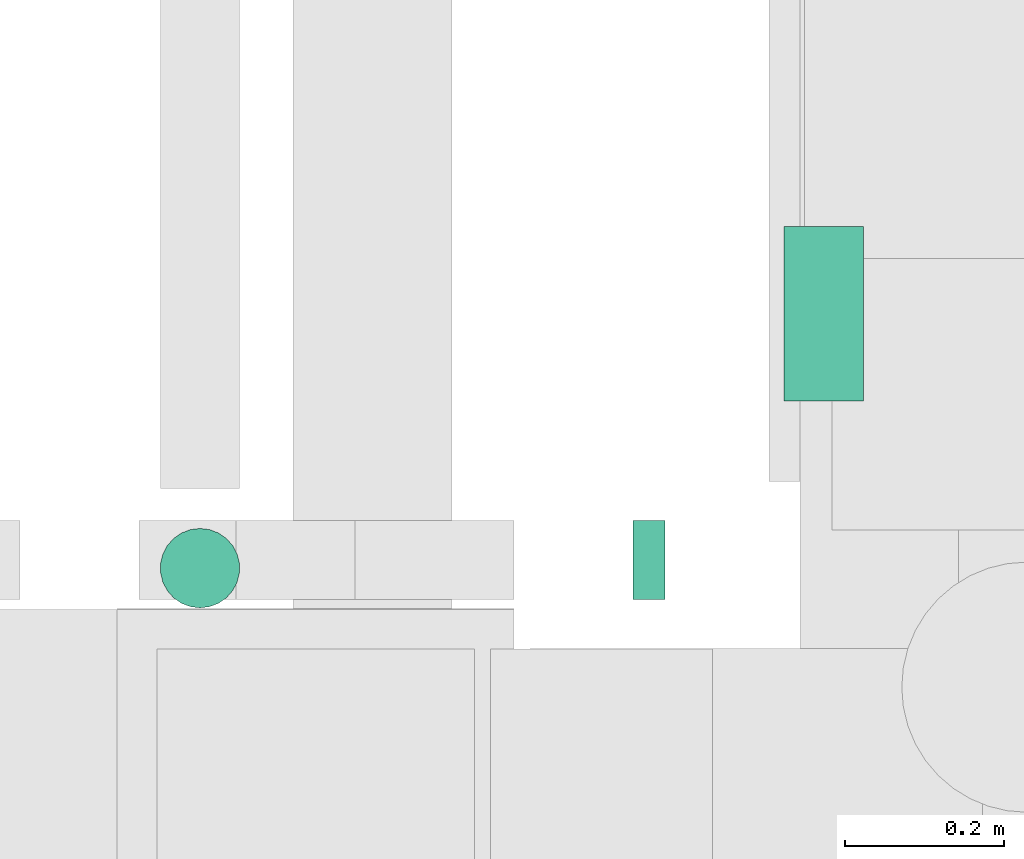
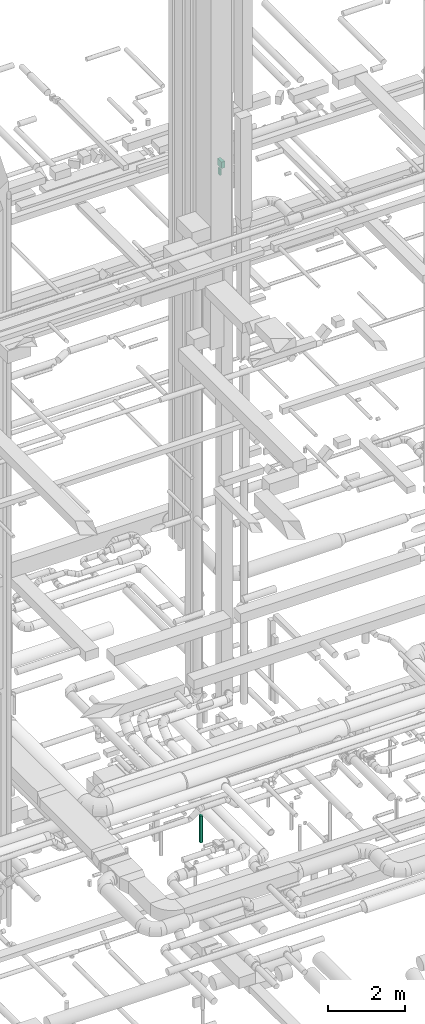
# One storey, part 199 of 337: 3 flow segments.
"""IFC2X3 building model written with IfcOpenShell, lengths in millimetres."""

import ifcopenshell
import ifcopenshell.guid

model = None  # the IFC model being written
_history = None  # IfcOwnerHistory: only IFC2X3 demands one
_inside = {}  # id of a spatial element -> (the spatial element, [elements in it])
_under = {}  # id of a project, library or spatial element -> (it, [spatial elements below it])
_declared = {}  # id of a project -> (the project, [libraries it declares])
_typed = {}  # id of a type object -> (the type object, [elements of that type])
_made_of = {}  # id of a material, layer set ... -> (it, [elements and type objects made of it])


def new_model(schema):
    """Start an empty IFC model of exactly this schema.

    Asked for "IFC4X3", IfcOpenShell would pick the latest addendum, in which some entities
    have other attributes; the version numbers below select the first issue.
    IFC2X3 requires an IfcOwnerHistory on every rooted entity: one is made here for all.
    """
    global model, _history
    if schema == "IFC4X3":
        model = ifcopenshell.file(schema_version=(4, 3, 0, 0))
    else:
        model = ifcopenshell.file(schema=schema)
    _inside.clear()
    _under.clear()
    _declared.clear()
    _typed.clear()
    _made_of.clear()
    _history = None
    if model.schema == "IFC2X3":
        org = make("IfcOrganization", Name="unknown")
        user = make(
            "IfcPersonAndOrganization",
            ThePerson=make("IfcPerson", FamilyName="unknown"),
            TheOrganization=org,
        )
        app = make(
            "IfcApplication",
            ApplicationDeveloper=org,
            Version="unknown",
            ApplicationFullName="unknown",
            ApplicationIdentifier="unknown",
        )
        _history = make(
            "IfcOwnerHistory",
            OwningUser=user,
            OwningApplication=app,
            ChangeAction="ADDED",
            CreationDate=0,
        )
    return model


def make(cls, **values):
    """One entity of the class cls with the attributes given. An attribute that is None is left unset."""
    return model.create_entity(
        cls, **{name: value for name, value in values.items() if value is not None}
    )


def entity(cls, *values):
    """Any entity or typed value of the class cls, its attributes in the order of the schema. None: left unset."""
    e = model.create_entity(cls)
    for i, value in enumerate(values):
        if value is not None:
            e[i] = value
    return e


def rooted(cls, **values):
    """An entity with a GlobalId (a new one), such as an element, a storey or a relation."""
    return make(cls, GlobalId=ifcopenshell.guid.new(), OwnerHistory=_history, **values)


def si_unit(unit_type, name, prefix=None):
    """IfcSIUnit, for example si_unit("LENGTHUNIT", "METRE", prefix="MILLI")."""
    return make("IfcSIUnit", UnitType=unit_type, Prefix=prefix, Name=name)


def converted_unit(unit_type, name, factor, base, dimensions=None, offset=None):
    """IfcConversionBasedUnit, such as the inch: factor (a typed value) times the base unit."""
    return make(
        "IfcConversionBasedUnit"
        if offset is None
        else "IfcConversionBasedUnitWithOffset",
        ConversionOffset=offset,
        Dimensions=None
        if dimensions is None
        else entity("IfcDimensionalExponents", *dimensions),
        UnitType=unit_type,
        Name=name,
        ConversionFactor=make(
            "IfcMeasureWithUnit", ValueComponent=factor, UnitComponent=base
        ),
    )


def derived_unit(unit_type, elements):
    """IfcDerivedUnit: a product of units, each with its exponent."""
    return make(
        "IfcDerivedUnit",
        Elements=[
            make("IfcDerivedUnitElement", Unit=unit, Exponent=power)
            for unit, power in elements
        ],
        UnitType=unit_type,
    )


def assignment(units):
    """IfcUnitAssignment: the units of a project."""
    return None if units is None else make("IfcUnitAssignment", Units=units)


def point(xyz):
    """IfcCartesianPoint."""
    return None if xyz is None else make("IfcCartesianPoint", Coordinates=xyz)


def direction(xyz):
    """IfcDirection."""
    return None if xyz is None else make("IfcDirection", DirectionRatios=xyz)


def frame(location, z_axis=None, x_axis=None):
    """IfcAxis2Placement3D, a coordinate frame: its origin and axes. An axis left out is left unset."""
    return make(
        "IfcAxis2Placement3D",
        Location=point(location),
        Axis=direction(z_axis),
        RefDirection=direction(x_axis),
    )


def frame_2d(location, x_axis=None):
    """IfcAxis2Placement2D, a coordinate frame in the plane: its origin and x axis."""
    return make(
        "IfcAxis2Placement2D", Location=point(location), RefDirection=direction(x_axis)
    )


def origin():
    """The frame at (0, 0, 0) with its axes left unset."""
    return frame((0.0, 0.0, 0.0))


def origin_2d_with_axis():
    """The frame at (0, 0) in the plane with the x axis (1, 0) written out."""
    return frame_2d((0.0, 0.0), x_axis=(1.0, 0.0))


def place(relative_to, where):
    """IfcLocalPlacement: puts the frame where relative to a parent placement (None: the world)."""
    return make(
        "IfcLocalPlacement", PlacementRelTo=relative_to, RelativePlacement=where
    )


def context(
    kind, dimensions, precision=None, world=None, true_north=None, identifier=None
):
    """IfcGeometricRepresentationContext, for example the 3D "Model" context."""
    return make(
        "IfcGeometricRepresentationContext",
        ContextIdentifier=identifier,
        ContextType=kind,
        CoordinateSpaceDimension=dimensions,
        Precision=precision,
        WorldCoordinateSystem=world,
        TrueNorth=true_north,
    )


def subcontext(parent, identifier, kind, view, scale=None):
    """IfcGeometricRepresentationSubContext, for example "Body" below "Model"."""
    return make(
        "IfcGeometricRepresentationSubContext",
        ContextIdentifier=identifier,
        ContextType=kind,
        ParentContext=parent,
        TargetScale=scale,
        TargetView=view,
    )


def project(units=None, contexts=None):
    """IfcProject with its units and contexts."""
    return rooted(
        "IfcProject",
        Name="project",
        RepresentationContexts=contexts,
        UnitsInContext=assignment(units),
    )


def spatial(cls, under=None, at=None, **own):
    """A site, building, storey or space (cls), placed at a placement, below another one or the project."""
    s = rooted(cls, ObjectPlacement=at, **own)
    if under is not None:
        _under.setdefault(under.id(), (under, []))[1].append(s)
    return s


def profile(cls, at=None, kind="AREA", **sizes):
    """A parametric profile (cls). Its sizes go by their IFC names, for example OverallWidth=200.0."""
    return make(cls, ProfileType=kind, Position=at, **sizes)


def rectangle(**sizes):
    """IfcRectangleProfileDef."""
    return profile("IfcRectangleProfileDef", **sizes)


def circle(**sizes):
    """IfcCircleProfileDef."""
    return profile("IfcCircleProfileDef", **sizes)


def extrude(swept, where, along, depth):
    """IfcExtrudedAreaSolid: the profile swept, set in the frame where, extruded along a direction by depth."""
    return make(
        "IfcExtrudedAreaSolid",
        SweptArea=swept,
        Position=where,
        ExtrudedDirection=direction(along),
        Depth=depth,
    )


def shape(context_of_items, identifier, shape_type, items):
    """IfcShapeRepresentation: the items that make up one representation, for example the "Body"."""
    return make(
        "IfcShapeRepresentation",
        ContextOfItems=context_of_items,
        RepresentationIdentifier=identifier,
        RepresentationType=shape_type,
        Items=items,
    )


def made_of(thing, what):
    """Note that an element or type object is made of a material, layer set ...; save() writes the relation."""
    if what is not None:
        _made_of.setdefault(what.id(), (what, []))[1].append(thing)
    return thing


def type_object(cls, material=None, **own):
    """A type object (cls), such as IfcWallType, which elements share."""
    return made_of(rooted(cls, **own), material)


def element(
    cls,
    number,
    at=None,
    inside=None,
    cuts=None,
    type_object=None,
    material=None,
    context=None,
    identifier="Body",
    shape_type=None,
    held_by="IfcProductDefinitionShape",
    body=None,
    shapes=None,
    **own,
):
    """One element of the class cls, such as IfcWall. Its Tag is "e" and its number.

    at: its placement. inside: the storey or other place that contains it. cuts: it is an
    opening in that element (IfcRelVoidsElement). A single representation is given by context,
    identifier, shape_type and body (its items); several are given by shapes. held_by: the class
    of the entity that holds the representations. save() writes the other relations.
    """
    e = rooted(cls, Tag="e%d" % number, ObjectPlacement=at, **own)
    if body is not None:
        shapes = [shape(context, identifier, shape_type, body)]
    if shapes is not None:
        e.Representation = make(held_by, Representations=shapes)
    if inside is not None:
        _inside.setdefault(inside.id(), (inside, []))[1].append(e)
    if cuts is not None:
        rooted(
            "IfcRelVoidsElement", RelatingBuildingElement=cuts, RelatedOpeningElement=e
        )
    if type_object is not None:
        _typed.setdefault(type_object.id(), (type_object, []))[1].append(e)
    return made_of(e, material)


def aggregate(whole, parts):
    """IfcRelAggregates: a whole, such as a stair, and the parts it consists of."""
    return rooted("IfcRelAggregates", RelatingObject=whole, RelatedObjects=parts)


def save(model, path):
    """Write the relations noted so far, then the file.

    IfcRelAggregates (storeys below a building ...), IfcRelContainedInSpatialStructure (elements
    in a storey), IfcRelDefinesByType, IfcRelAssociatesMaterial and IfcRelDeclares: one each for
    every whole, place, type object, material and project.
    """
    for whole, parts in _under.values():
        aggregate(whole, parts)
    for where, things in _inside.values():
        rooted(
            "IfcRelContainedInSpatialStructure",
            RelatedElements=things,
            RelatingStructure=where,
        )
    for kind, things in _typed.values():
        rooted("IfcRelDefinesByType", RelatedObjects=things, RelatingType=kind)
    for what, things in _made_of.values():
        rooted("IfcRelAssociatesMaterial", RelatedObjects=things, RelatingMaterial=what)
    for by, libraries in _declared.values():
        rooted("IfcRelDeclares", RelatingContext=by, RelatedDefinitions=libraries)
    model.write(path)


model = new_model("IFC2X3")

# Units and contexts
model_context = context("Model", 3, precision=0.01, world=origin(), true_north=direction((6.12303176911189e-17, 1.0)))
body_context = subcontext(model_context, "Body", "Model", "MODEL_VIEW")
ifc_project = project(units=[si_unit("LENGTHUNIT", "METRE", prefix="MILLI"), si_unit("AREAUNIT", "SQUARE_METRE"), si_unit("VOLUMEUNIT", "CUBIC_METRE"), converted_unit("PLANEANGLEUNIT", "DEGREE", entity("IfcRatioMeasure", 0.0174532925199433), si_unit("PLANEANGLEUNIT", "RADIAN"), dimensions=[0, 0, 0, 0, 0, 0, 0]), si_unit("MASSUNIT", "GRAM", prefix="KILO"), derived_unit("MASSDENSITYUNIT", [(si_unit("MASSUNIT", "GRAM", prefix="KILO"), 1), (si_unit("LENGTHUNIT", "METRE"), -3)]), derived_unit("MOMENTOFINERTIAUNIT", [(si_unit("LENGTHUNIT", "METRE"), 4)]), si_unit("TIMEUNIT", "SECOND"), si_unit("FREQUENCYUNIT", "HERTZ"), si_unit("THERMODYNAMICTEMPERATUREUNIT", "DEGREE_CELSIUS"), derived_unit("THERMALTRANSMITTANCEUNIT", [(si_unit("MASSUNIT", "GRAM", prefix="KILO"), 1), (si_unit("THERMODYNAMICTEMPERATUREUNIT", "KELVIN"), -1), (si_unit("TIMEUNIT", "SECOND"), -3)]), derived_unit("VOLUMETRICFLOWRATEUNIT", [(si_unit("LENGTHUNIT", "METRE"), 3), (si_unit("TIMEUNIT", "SECOND"), -1)]), derived_unit("MASSFLOWRATEUNIT", [(si_unit("MASSUNIT", "GRAM", prefix="KILO"), 1), (si_unit("TIMEUNIT", "SECOND"), -1)]), derived_unit("ROTATIONALFREQUENCYUNIT", [(si_unit("TIMEUNIT", "SECOND"), -1)]), si_unit("ELECTRICCURRENTUNIT", "AMPERE"), si_unit("ELECTRICVOLTAGEUNIT", "VOLT"), si_unit("POWERUNIT", "WATT"), si_unit("FORCEUNIT", "NEWTON", prefix="KILO"), si_unit("ILLUMINANCEUNIT", "LUX"), si_unit("LUMINOUSFLUXUNIT", "LUMEN"), si_unit("LUMINOUSINTENSITYUNIT", "CANDELA"), derived_unit("USERDEFINED", [(si_unit("MASSUNIT", "GRAM", prefix="KILO"), -1), (si_unit("LENGTHUNIT", "METRE"), -2), (si_unit("TIMEUNIT", "SECOND"), 3), (si_unit("LUMINOUSFLUXUNIT", "LUMEN"), 1)]), derived_unit("LINEARVELOCITYUNIT", [(si_unit("LENGTHUNIT", "METRE"), 1), (si_unit("TIMEUNIT", "SECOND"), -1)]), si_unit("PRESSUREUNIT", "PASCAL"), derived_unit("USERDEFINED", [(si_unit("LENGTHUNIT", "METRE"), -2), (si_unit("MASSUNIT", "GRAM", prefix="KILO"), 1), (si_unit("TIMEUNIT", "SECOND"), -2)]), derived_unit("LINEARFORCEUNIT", [(si_unit("MASSUNIT", "GRAM", prefix="KILO"), 1), (si_unit("LENGTHUNIT", "METRE"), 1), (si_unit("TIMEUNIT", "SECOND"), -2), (si_unit("LENGTHUNIT", "METRE"), -1)]), derived_unit("PLANARFORCEUNIT", [(si_unit("MASSUNIT", "GRAM", prefix="KILO"), 1), (si_unit("LENGTHUNIT", "METRE"), 1), (si_unit("TIMEUNIT", "SECOND"), -2), (si_unit("LENGTHUNIT", "METRE"), -2)])], contexts=[model_context])

# Site, building, storey
site_placement = place(None, origin())
site = spatial("IfcSite", under=ifc_project, at=site_placement, CompositionType="ELEMENT")
building_placement = place(site_placement, origin())
building = spatial("IfcBuilding", under=site, at=building_placement, CompositionType="ELEMENT")
storey_placement = place(building_placement, origin())
storey = spatial("IfcBuildingStorey", under=building, at=storey_placement, CompositionType="ELEMENT", Elevation=0.0)

# Flow segments
duct_segment_type_1 = type_object("IfcDuctSegmentType", PredefinedType="NOTDEFINED")
flow_segment_1_placement = place(storey_placement, frame((53089.92, 13253.66, 19150.0)))
element("IfcFlowSegment", 1, at=flow_segment_1_placement, inside=storey, type_object=duct_segment_type_1, context=body_context, shape_type="SweptSolid", body=[
    extrude(rectangle(XDim=220.000000000065, YDim=100.000000000003, at=origin_2d_with_axis()), frame((50.0, 110.0, 0.0), z_axis=(0.0, 0.0, 1.0), x_axis=(0.0, 1.0, 0.0)), (0.0, 0.0, 1.0), 199.999999999998),
])
flow_segment_2_placement = place(storey_placement, frame((52899.92, 13003.66, 19150.0)))
element("IfcFlowSegment", 2, at=flow_segment_2_placement, inside=storey, type_object=duct_segment_type_1, context=body_context, shape_type="SweptSolid", body=[
    extrude(rectangle(XDim=40.0000000000256, YDim=99.9999999999989, at=origin_2d_with_axis()), frame((20.0, 50.0, 0.0), z_axis=(0.0, 0.0, 1.0), x_axis=(-1.0, 0.0, 0.0)), (0.0, 0.0, 1.0), 199.999999999998),
])
duct_segment_type_2 = type_object("IfcDuctSegmentType", PredefinedType="NOTDEFINED")
flow_segment_3_placement = place(storey_placement, frame((52303.03, 12991.8, -1800.0)))
element("IfcFlowSegment", 3, at=flow_segment_3_placement, inside=storey, type_object=duct_segment_type_2, context=body_context, shape_type="SweptSolid", body=[
    extrude(circle(Radius=50.0, at=origin_2d_with_axis()), frame((51.6, 51.6, 0.0), z_axis=(0.0, 0.0, 1.0), x_axis=(0.0, 1.0, 0.0)), (0.0, 0.0, 1.0), 849.999999999999),
])

save(model, "model.ifc")
